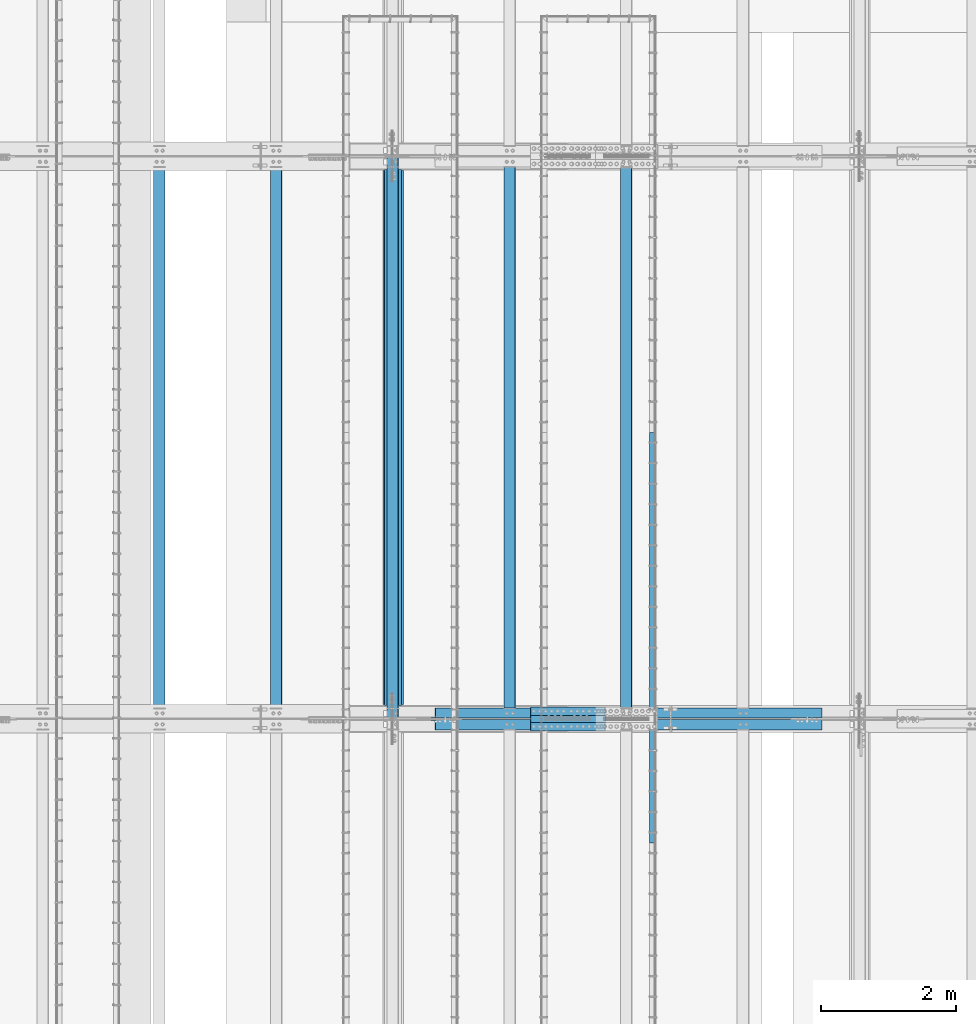
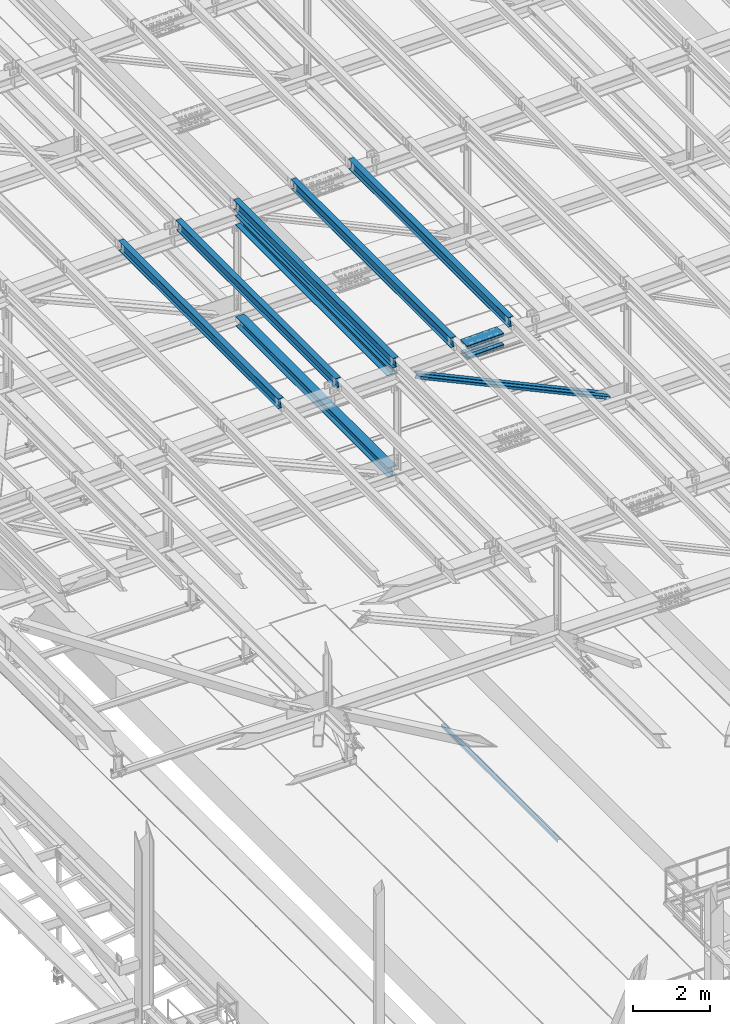
# One storey, part 1828 of 3843: 14 beams, 2 members, 11 elements without a shape of their own.
"""IFC2X3 building model written with IfcOpenShell, lengths in millimetres."""

from ifc_helpers import new_model, si_unit, frame, origin_with_axes, place, context, subcontext, project, spatial, faceted_brep, material, type_object, element, aggregate, save


model = new_model("IFC2X3")

# Units and contexts
model_context = context("Model", 3, precision=1e-05, world=origin_with_axes())
body_context = subcontext(model_context, "Body", "Model", "MODEL_VIEW")
ifc_project = project(units=[si_unit("LENGTHUNIT", "METRE", prefix="MILLI"), si_unit("AREAUNIT", "SQUARE_METRE"), si_unit("VOLUMEUNIT", "CUBIC_METRE"), si_unit("MASSUNIT", "GRAM", prefix="KILO"), si_unit("TIMEUNIT", "SECOND"), si_unit("PLANEANGLEUNIT", "RADIAN"), si_unit("SOLIDANGLEUNIT", "STERADIAN"), si_unit("THERMODYNAMICTEMPERATUREUNIT", "DEGREE_CELSIUS"), si_unit("LUMINOUSINTENSITYUNIT", "LUMEN")], contexts=[model_context])

# Site, building, storey
site_placement = place(None, origin_with_axes())
site = spatial("IfcSite", under=ifc_project, at=site_placement, CompositionType="ELEMENT")
building_placement = place(site_placement, origin_with_axes())
building = spatial("IfcBuilding", under=site, at=building_placement, Name="Undefined", CompositionType="ELEMENT")
storey_placement = place(building_placement, origin_with_axes())
storey = spatial("IfcBuildingStorey", under=building, at=storey_placement, Name="Undefined", CompositionType="ELEMENT", Elevation=0.0)

# Assembly, beam
assembly_1_placement = place(storey_placement, origin_with_axes())
assembly_1 = element("IfcElementAssembly", 1, at=assembly_1_placement, inside=storey, Name="EMBED_ANGLE", AssemblyPlace="NOTDEFINED", PredefinedType="RIGID_FRAME")
ifc_material_1 = material(Name="STEEL/A36")
beam_type_1 = type_object("IfcBeamType", Name="L3-1/2X3-1/2X5/16", PredefinedType="NOTDEFINED")
beam_1_placement = place(assembly_1_placement, frame((52851.7485419922, 46456.599609375, 30410.15), z_axis=(0.0, 0.0, -1.0), x_axis=(0.0, -1.0, 0.0)))
beam_1 = element("IfcBeam", 2, at=beam_1_placement, type_object=beam_type_1, material=ifc_material_1, Name="EMBED_ANGLE", ObjectType="L3-1/2X3-1/2X5/16", context=body_context, shape_type="Brep", body=[
    faceted_brep([(-3.63797880709171e-12, 44.4499999999971, -44.4500000000007), (-3.63797880709171e-12, 44.4499999999971, 44.4500000000007), (6096.0, 44.4499999999971, 44.4500000000007), (6096.0, 44.4499999999971, -44.4500000000007), (-3.63797880709171e-12, 36.5124999999971, 44.4500000000007), (6096.0, 36.5124999999971, 44.4500000000007), (-3.63797880709171e-12, 36.5124999999971, -36.5125000000007), (6096.0, 36.5124999999971, -36.5125000000007), (3.63797880709171e-12, -44.4499999999971, -36.5125000000007), (6096.0, -44.4499999999971, -36.5125000000007), (3.63797880709171e-12, -44.4499999999971, -44.4500000000007), (6096.0, -44.4499999999971, -44.4500000000007)], [[[0, 1, 2, 3]], [[1, 4, 5, 2]], [[4, 6, 7, 5]], [[6, 8, 9, 7]], [[8, 10, 11, 9]], [[10, 0, 3, 11]], [[5, 7, 9, 11, 3, 2]], [[10, 8, 6, 4, 1, 0]]]),
])
aggregate(assembly_1, [beam_1])

assembly_2_placement = place(storey_placement, origin_with_axes())
assembly_2 = element("IfcElementAssembly", 3, at=assembly_2_placement, inside=storey, Name="BEAM", AssemblyPlace="NOTDEFINED", PredefinedType="RIGID_FRAME")
ifc_material_2 = material(Name="STEEL/A992")
beam_type_2 = type_object("IfcBeamType", Name="W12X26", PredefinedType="NOTDEFINED")
beam_2_placement = place(assembly_2_placement, frame((48993.309262352, 42201.9275446702, 45888.5906251913), z_axis=(-0.0211520980083369, -0.00110850299980666, 0.999775654820093), x_axis=(0.0, 0.999999385335421, 0.00110875100037148)))
beam_2 = element("IfcBeam", 4, at=beam_2_placement, type_object=beam_type_2, material=ifc_material_2, Name="BEAM", ObjectType="W12X26", context=body_context, shape_type="Brep", body=[
    faceted_brep([(12.6980717942206, 82.5500000002139, -155.574999999408), (12.7086302911775, 82.5500000001921, -146.049999999421), (8343.91375117049, 82.5500000003813, -146.050000008639), (8343.90319267353, 82.5500000004031, -155.575000008612), (12.710491827158, 3.17500000034488, -146.049999999675), (8343.91561270646, 3.17500000053406, -146.050000008887), (13.0342857339128, 3.17499999964639, 146.049999999668), (8344.23940661321, 3.17499999983556, 146.049999990464), (13.0324241979324, 82.5499999994863, 146.049999999916), (8344.23754507724, 82.5499999996755, 146.049999990704), (13.0429826948894, 82.5499999994718, 155.574999999895), (8344.2481035742, 82.5499999996609, 155.574999990684), (13.0468546897246, -82.5500000002139, 155.574999999386), (8344.25197556902, -82.5500000000247, 155.574999990175), (13.0362961927676, -82.5500000001848, 146.049999999406), (8344.24141707207, -82.5499999999956, 146.049999990188), (13.0344346567872, -3.17500000034488, 146.049999999654), (8344.23955553609, -3.17500000015571, 146.049999990442), (12.7106407500323, -3.17499999963911, -146.04999999969), (8343.91576162934, -3.17499999944994, -146.050000008901), (12.7125022860055, -82.5499999994863, -146.049999999937), (8343.91762316532, -82.5499999992971, -146.050000009149), (12.7019437890485, -82.5499999994645, -155.57499999991), (8343.90706466835, -82.5499999992753, -155.575000009128)], [[[0, 1, 2, 3]], [[1, 4, 5, 2]], [[4, 6, 7, 5]], [[6, 8, 9, 7]], [[8, 10, 11, 9]], [[10, 12, 13, 11]], [[12, 14, 15, 13]], [[14, 16, 17, 15]], [[16, 18, 19, 17]], [[18, 20, 21, 19]], [[20, 22, 23, 21]], [[22, 0, 3, 23]], [[5, 7, 9, 11, 13, 15, 17, 19, 21, 23, 3, 2]], [[22, 20, 18, 16, 14, 12, 10, 8, 6, 4, 1, 0]]]),
])
aggregate(assembly_2, [beam_2])

assembly_3_placement = place(storey_placement, origin_with_axes())
assembly_3 = element("IfcElementAssembly", 5, at=assembly_3_placement, inside=storey, Name="BEAM", AssemblyPlace="NOTDEFINED", PredefinedType="RIGID_FRAME")
beam_3_placement = place(assembly_3_placement, frame((52460.4092622945, 42201.8902388067, 45971.7715925122), z_axis=(-0.0211520982424918, -0.00134829600025114, 0.999775360187395), x_axis=(0.0, 0.999999090641304, 0.00134859799951611)))
beam_3 = element("IfcBeam", 6, at=beam_3_placement, type_object=beam_type_2, material=ifc_material_2, Name="BEAM", ObjectType="W12X26", context=body_context, shape_type="Brep", body=[
    faceted_brep([(12.6976567514139, 82.5500000003303, -155.575000000208), (12.7104992851673, 82.5500000003085, -146.050000000199), (8343.91807537855, 82.5499999999302, -146.049999982519), (8343.9052328448, 82.549999999952, -155.57499998252), (12.7127635129655, 3.17500000043947, -146.050000000076), (8343.92033960635, 3.17500000006112, -146.04999998241), (13.106601214713, 3.1749999995518, 146.050000000134), (8344.3141773081, 3.17499999917345, 146.050000017814), (13.1043369869221, 82.5499999994136, 146.050000000025), (8344.3119130803, 82.5499999990352, 146.050000017698), (13.1171795206756, 82.5499999993917, 155.575000000033), (8344.32475561406, 82.5499999990134, 155.575000017707), (13.121889114489, -82.5500000003303, 155.575000000266), (8344.32946520787, -82.5500000007087, 155.575000017947), (13.1090465807356, -82.5500000003085, 146.050000000265), (8344.31662267412, -82.5500000006869, 146.050000017945), (13.1067823529447, -3.17500000043947, 146.050000000156), (8344.31435844633, -3.17500000081782, 146.050000017829), (12.7129446511899, -3.1749999995518, -146.050000000068), (8343.92052074457, -3.17499999993015, -146.049999982388), (12.7152088789881, -82.5499999994136, -146.049999999945), (8343.92278497236, -82.5499999997919, -146.049999982279), (12.7023663452273, -82.5499999993917, -155.574999999961), (8343.90994243861, -82.5499999997701, -155.574999982287)], [[[0, 1, 2, 3]], [[1, 4, 5, 2]], [[4, 6, 7, 5]], [[6, 8, 9, 7]], [[8, 10, 11, 9]], [[10, 12, 13, 11]], [[12, 14, 15, 13]], [[14, 16, 17, 15]], [[16, 18, 19, 17]], [[18, 20, 21, 19]], [[20, 22, 23, 21]], [[22, 0, 3, 23]], [[5, 7, 9, 11, 13, 15, 17, 19, 21, 23, 3, 2]], [[22, 20, 18, 16, 14, 12, 10, 8, 6, 4, 1, 0]]]),
])
aggregate(assembly_3, [beam_3])

assembly_4_placement = place(storey_placement, origin_with_axes())
assembly_4 = element("IfcElementAssembly", 7, at=assembly_4_placement, inside=storey, Name="BEAM", AssemblyPlace="NOTDEFINED", PredefinedType="RIGID_FRAME")
beam_4_placement = place(assembly_4_placement, frame((50726.859262296, 42201.9083142255, 45930.4266750726), z_axis=(-0.0211520980705027, -0.00123211200015067, 0.999775510125766), x_axis=(0.0, 0.999999240610853, 0.00123238699952042)))
beam_4 = element("IfcBeam", 8, at=beam_4_placement, type_object=beam_type_2, material=ifc_material_2, Name="BEAM", ObjectType="W12X26", context=body_context, shape_type="Brep", body=[
    faceted_brep([(12.6978578274429, 82.5500000001193, -155.575000000354), (12.7095936962578, 82.5500000001048, -146.050000000345), (8343.91592028135, 82.5500000007305, -146.050000029805), (8343.90418441253, 82.5500000007378, -155.575000029814), (12.7116628110161, 3.17500000023574, -146.050000000105), (8343.91798939612, 3.1750000008542, -146.05000002958), (13.0715627881727, 3.17499999975553, 146.050000000003), (8344.27788937327, 3.17500000037398, 146.04999997055), (13.0694936734144, 82.5499999996173, 146.049999999763), (8344.27582025851, 82.5500000002357, 146.049999970302), (13.0812295422365, 82.5499999996027, 155.574999999772), (8344.28755612733, 82.5500000002212, 155.574999970311), (13.0855333009458, -82.5500000001193, 155.575000000274), (8344.29185988603, -82.5499999994936, 155.574999970806), (13.0737974321237, -82.5500000000975, 146.050000000265), (8344.28012401721, -82.549999999479, 146.049999970804), (13.0717283173581, -3.17500000023574, 146.050000000017), (8344.27805490245, -3.17499999961001, 146.049999970564), (12.7118283402015, -3.17499999975553, -146.05000000009), (8343.9181549253, -3.17499999913707, -146.050000029558), (12.7138974549671, -82.5499999996173, -146.049999999843), (8343.92022404006, -82.5499999989916, -146.05000002931), (12.7021615861449, -82.5499999996027, -155.574999999852), (8343.90848817123, -82.549999998977, -155.575000029312)], [[[0, 1, 2, 3]], [[1, 4, 5, 2]], [[4, 6, 7, 5]], [[6, 8, 9, 7]], [[8, 10, 11, 9]], [[10, 12, 13, 11]], [[12, 14, 15, 13]], [[14, 16, 17, 15]], [[16, 18, 19, 17]], [[18, 20, 21, 19]], [[20, 22, 23, 21]], [[22, 0, 3, 23]], [[5, 7, 9, 11, 13, 15, 17, 19, 21, 23, 3, 2]], [[22, 20, 18, 16, 14, 12, 10, 8, 6, 4, 1, 0]]]),
])
aggregate(assembly_4, [beam_4])

assembly_5_placement = place(storey_placement, origin_with_axes())
assembly_5 = element("IfcElementAssembly", 9, at=assembly_5_placement, inside=storey, Name="BEAM", AssemblyPlace="NOTDEFINED", PredefinedType="RIGID_FRAME")
beam_5_placement = place(assembly_5_placement, frame((47259.7592622956, 42201.9479393539, 45846.2543835782), z_axis=(-0.0211520981155117, -0.00097741099957784, 0.999775791571815), x_axis=(0.0, 0.999999522120655, 0.000977629000118257)))
beam_5 = element("IfcBeam", 10, at=beam_5_placement, type_object=beam_type_2, material=ifc_material_2, Name="BEAM", ObjectType="W12X26", context=body_context, shape_type="Brep", body=[
    faceted_brep([(12.6982990667166, 82.5499999994063, -155.57500000007), (12.7076089040711, 82.5499999994354, -146.050000000047), (8343.91159024316, 82.5499999989988, -146.04999997947), (8343.90224609679, 82.5499999801978, -155.574999994402), (12.7092502928863, 3.17499999959546, -146.050000000258), (8343.91323163197, 3.1749999991589, -146.049999979667), (12.9947519717607, 3.17500000038854, 146.05000000033), (8344.19873331086, 3.17499999995198, 146.050000020921), (12.9931105829455, 82.5500000002285, 146.050000000541), (8344.19709192203, 82.5499999997919, 146.050000021118), (13.0024204203, 82.5500000002576, 155.575000000557), (8344.20640175939, 82.549999999821, 155.575000021148), (13.0058345090365, -82.5499999994063, 155.575000000128), (8344.20981584812, -82.5499999998428, 155.575000020712), (12.996524671682, -82.5499999994354, 146.050000000112), (8344.20050601077, -82.5499999998719, 146.050000020696), (12.9948832828668, -3.17499999959546, 146.050000000323), (8344.19886462195, -3.17500000003201, 146.050000020899), (12.7093816039924, -3.17500000038854, -146.050000000272), (8343.91336294308, -3.17500000082509, -146.049999979688), (12.7110229928076, -82.5500000002212, -146.050000000483), (8343.9150043319, -82.5500000006577, -146.049999979892), (12.7017131554458, -82.5500000002576, -155.575000000499), (8343.90569449455, -82.5500000006941, -155.574999979923)], [[[0, 1, 2, 3]], [[1, 4, 5, 2]], [[4, 6, 7, 5]], [[6, 8, 9, 7]], [[8, 10, 11, 9]], [[10, 12, 13, 11]], [[12, 14, 15, 13]], [[14, 16, 17, 15]], [[16, 18, 19, 17]], [[18, 20, 21, 19]], [[20, 22, 23, 21]], [[22, 0, 3, 23]], [[5, 7, 9, 11, 13, 15, 17, 19, 21, 23, 3, 2]], [[22, 20, 18, 16, 14, 12, 10, 8, 6, 4, 1, 0]]]),
])
aggregate(assembly_5, [beam_5])

assembly_6_placement = place(storey_placement, origin_with_axes())
assembly_6 = element("IfcElementAssembly", 11, at=assembly_6_placement, inside=storey, Name="BEAM", AssemblyPlace="NOTDEFINED", PredefinedType="RIGID_FRAME")
beam_6_placement = place(assembly_6_placement, frame((45526.209262296, 42201.9695298362, 45803.4044011888), z_axis=(-0.0211520984488161, -0.000838631999671634, 0.999775917607331), x_axis=(0.0, 0.999999648190442, 0.000838820000159733)))
beam_6 = element("IfcBeam", 12, at=beam_6_placement, type_object=beam_type_2, material=ifc_material_2, Name="BEAM", ObjectType="W12X26", context=body_context, shape_type="Brep", body=[
    faceted_brep([(12.6985397381141, 82.5499999995518, -155.575000000288), (12.7065277138609, 82.5499999995591, -146.050000000272), (8343.90945875162, 82.54999999953, -146.049999998671), (8343.9014659344, 82.5499999790045, -155.574999985372), (12.7079360494827, 3.17499999971915, -146.050000000258), (8343.91086708724, 3.17499999969004, -146.049999998664), (12.9529006390876, 3.17500000025757, 146.050000000279), (8344.15583167685, 3.17500000022847, 146.050000001873), (12.9514923034731, 82.5500000000975, 146.050000000272), (8344.15442334124, 82.5500000000684, 146.050000001858), (12.9594802792199, 82.5500000001193, 155.575000000281), (8344.16241131699, 82.5500000000829, 155.575000001889), (12.9624096173065, -82.5499999995591, 155.575000000295), (8344.16534065507, -82.5499999995882, 155.575000001903), (12.9544216415597, -82.5499999995736, 146.050000000287), (8344.15735267932, -82.54999999961, 146.050000001887), (12.9530133059379, -3.17499999972642, 146.050000000279), (8344.15594434371, -3.1749999997628, 146.050000001873), (12.7080487163257, -3.17500000026484, -146.050000000258), (8343.9109797541, -3.17500000029395, -146.049999998664), (12.7094570519475, -82.5500000001048, -146.05000000025), (8343.91238808972, -82.5500000001339, -146.049999998657), (12.7014690762007, -82.5500000001339, -155.575000000266), (8343.90440011397, -82.550000000163, -155.57499999868)], [[[0, 1, 2, 3]], [[1, 4, 5, 2]], [[4, 6, 7, 5]], [[6, 8, 9, 7]], [[8, 10, 11, 9]], [[10, 12, 13, 11]], [[12, 14, 15, 13]], [[14, 16, 17, 15]], [[16, 18, 19, 17]], [[18, 20, 21, 19]], [[20, 22, 23, 21]], [[22, 0, 3, 23]], [[5, 7, 9, 11, 13, 15, 17, 19, 21, 23, 3, 2]], [[22, 20, 18, 16, 14, 12, 10, 8, 6, 4, 1, 0]]]),
])
aggregate(assembly_6, [beam_6])

# Assembly, beams
assembly_7_placement = place(storey_placement, origin_with_axes())
assembly_7 = element("IfcElementAssembly", 13, at=assembly_7_placement, inside=storey, Name="BEAM", AssemblyPlace="NOTDEFINED", PredefinedType="RIGID_FRAME")
ifc_material_3 = material(Name="STEEL/A572-50")
beam_type_3 = type_object("IfcBeamType", PredefinedType="NOTDEFINED")
beam_7_placement = place(assembly_7_placement, frame((51036.2821626709, 42316.4, 45732.9991056913), z_axis=(0.0, -1.0, 0.0), x_axis=(0.999715775508226, 0.0, 0.0238404739882768)))
beam_7 = element("IfcBeam", 14, at=beam_7_placement, type_object=beam_type_3, material=ifc_material_3, Name="PLATE", context=body_context, shape_type="Brep", body=[
    faceted_brep([(-4.36557456851006e-11, 12.7000000000116, -63.5), (-4.36557456851006e-11, 12.7000000000116, 63.5), (1104.90000001677, 12.7000000017251, 63.5), (1104.90000001677, 12.7000000017251, -63.5), (1.45519152283669e-11, -12.700000000008, 63.5), (1104.90000001682, -12.6999999982909, 63.5), (1.45519152283669e-11, -12.700000000008, -63.5), (1104.90000001682, -12.6999999982909, -63.5)], [[[0, 1, 2, 3]], [[1, 4, 5, 2]], [[4, 6, 7, 5]], [[6, 0, 3, 7]], [[5, 7, 3, 2]], [[6, 4, 1, 0]]]),
])
beam_8_placement = place(assembly_7_placement, frame((51043.3215559645, 42316.4, 45437.8123355448), z_axis=(0.0, -1.0, 0.0), x_axis=(0.999715775508226, 0.0, 0.0238404739882768)))
beam_8 = element("IfcBeam", 15, at=beam_8_placement, type_object=beam_type_3, material=ifc_material_3, Name="PLATE", context=body_context, shape_type="Brep", body=[
    faceted_brep([(-4.36557456851006e-11, 12.7000000000116, -63.5), (-4.36557456851006e-11, 12.7000000000116, 63.5), (1104.90000001677, 12.7000000017251, 63.5), (1104.90000001677, 12.7000000017251, -63.5), (1.45519152283669e-11, -12.700000000008, 63.5), (1104.90000001682, -12.6999999982909, 63.5), (1.45519152283669e-11, -12.700000000008, -63.5), (1104.90000001682, -12.6999999982909, -63.5)], [[[0, 1, 2, 3]], [[1, 4, 5, 2]], [[4, 6, 7, 5]], [[6, 0, 3, 7]], [[5, 7, 3, 2]], [[6, 4, 1, 0]]]),
])
beam_9_placement = place(assembly_7_placement, frame((51036.2821626709, 42087.8, 45732.9991056913), z_axis=(0.0, -1.0, 0.0), x_axis=(0.999715775508226, 0.0, 0.0238404739882768)))
beam_9 = element("IfcBeam", 16, at=beam_9_placement, type_object=beam_type_3, material=ifc_material_3, Name="PLATE", context=body_context, shape_type="Brep", body=[
    faceted_brep([(-4.36557456851006e-11, 12.7000000000116, -63.5), (-4.36557456851006e-11, 12.7000000000116, 63.5), (1104.90000001677, 12.7000000017251, 63.5), (1104.90000001677, 12.7000000017251, -63.5), (1.45519152283669e-11, -12.700000000008, 63.5), (1104.90000001682, -12.6999999982909, 63.5), (1.45519152283669e-11, -12.700000000008, -63.5), (1104.90000001682, -12.6999999982909, -63.5)], [[[0, 1, 2, 3]], [[1, 4, 5, 2]], [[4, 6, 7, 5]], [[6, 0, 3, 7]], [[5, 7, 3, 2]], [[6, 4, 1, 0]]]),
])
beam_10_placement = place(assembly_7_placement, frame((51043.3215559645, 42087.8, 45437.8123355448), z_axis=(0.0, -1.0, 0.0), x_axis=(0.999715775508226, 0.0, 0.0238404739882768)))
beam_10 = element("IfcBeam", 17, at=beam_10_placement, type_object=beam_type_3, material=ifc_material_3, Name="PLATE", context=body_context, shape_type="Brep", body=[
    faceted_brep([(-4.36557456851006e-11, 12.7000000000116, -63.5), (-4.36557456851006e-11, 12.7000000000116, 63.5), (1104.90000001677, 12.7000000017251, 63.5), (1104.90000001677, 12.7000000017251, -63.5), (1.45519152283669e-11, -12.700000000008, 63.5), (1104.90000001682, -12.6999999982909, 63.5), (1.45519152283669e-11, -12.700000000008, -63.5), (1104.90000001682, -12.6999999982909, -63.5)], [[[0, 1, 2, 3]], [[1, 4, 5, 2]], [[4, 6, 7, 5]], [[6, 0, 3, 7]], [[5, 7, 3, 2]], [[6, 4, 1, 0]]]),
])
beam_type_4 = type_object("IfcBeamType", PredefinedType="NOTDEFINED")
beam_11_placement = place(assembly_7_placement, frame((52139.3904600883, 42202.1, 45821.3041020251), z_axis=(0.0, -1.0, 0.0), x_axis=(-0.999715775508227, 0.0, -0.0238404739882678)))
beam_11 = element("IfcBeam", 18, at=beam_11_placement, type_object=beam_type_4, material=ifc_material_3, Name="PLATE", context=body_context, shape_type="Brep", body=[
    faceted_brep([(-1.45519152283669e-11, 12.7000000000025, -177.800000000003), (-1.45519152283669e-11, 12.7000000000025, 177.800000000003), (1104.90000001682, 12.7000000017051, 177.800000000003), (1104.90000001682, 12.7000000017051, -177.800000000003), (4.36557456851006e-11, -12.7000000000171, 177.800000000003), (1104.90000001686, -12.6999999983072, 177.800000000003), (4.36557456851006e-11, -12.7000000000171, -177.800000000003), (1104.90000001686, -12.6999999983072, -177.800000000003)], [[[0, 1, 2, 3]], [[1, 4, 5, 2]], [[4, 6, 7, 5]], [[6, 0, 3, 7]], [[5, 7, 3, 2]], [[6, 4, 1, 0]]]),
])
beam_12_placement = place(assembly_7_placement, frame((52149.3857265386, 42202.1, 45402.2588242328), z_axis=(0.0, -1.0, 0.0), x_axis=(-0.999715775508227, 0.0, -0.0238404739882678)))
beam_12 = element("IfcBeam", 19, at=beam_12_placement, type_object=beam_type_4, material=ifc_material_3, Name="PLATE", context=body_context, shape_type="Brep", body=[
    faceted_brep([(-1.45519152283669e-11, 12.7000000000025, -177.800000000003), (-1.45519152283669e-11, 12.7000000000025, 177.800000000003), (1104.90000001682, 12.7000000017051, 177.800000000003), (1104.90000001682, 12.7000000017051, -177.800000000003), (4.36557456851006e-11, -12.7000000000171, 177.800000000003), (1104.90000001686, -12.6999999983072, 177.800000000003), (4.36557456851006e-11, -12.7000000000171, -177.800000000003), (1104.90000001686, -12.6999999983072, -177.800000000003)], [[[0, 1, 2, 3]], [[1, 4, 5, 2]], [[4, 6, 7, 5]], [[6, 0, 3, 7]], [[5, 7, 3, 2]], [[6, 4, 1, 0]]]),
])
aggregate(assembly_7, [beam_7, beam_8, beam_9, beam_10, beam_11, beam_12])

# Assembly, member
assembly_8_placement = place(storey_placement, origin_with_axes())
assembly_8 = element("IfcElementAssembly", 20, at=assembly_8_placement, inside=storey, Name="ANGLE", AssemblyPlace="NOTDEFINED", PredefinedType="RIGID_FRAME")
member_type = type_object("IfcMemberType", Name="L6X6X1/2", PredefinedType="NOTDEFINED")
member_1_placement = place(assembly_8_placement, frame((48996.5999997284, 42287.825, 45536.1429226024), z_axis=(-0.421177373026855, 0.0, -0.906978291057839), x_axis=(0.906978291057838, 0.0, -0.421177373026857)))
member_1 = element("IfcMember", 21, at=member_1_placement, type_object=member_type, material=ifc_material_3, Name="ANGLE", ObjectType="L6X6X1/2", context=body_context, shape_type="Brep", body=[
    faceted_brep([(655.376403827697, 76.1999999999971, -76.2000000000626), (655.376403827697, 76.1999999999971, 76.2000000001717), (6990.08542977147, 76.1999999999971, 76.200000000812), (6990.08542977147, 76.1999999999971, -76.1999999994296), (655.376403827697, 63.5, 76.2000000001717), (6990.08542977147, 63.5, 76.200000000812), (655.3764038277, 63.5, -63.5000000000437), (6990.08542977146, 63.5, -63.4999999994106), (655.3764038277, -76.1999999999971, -63.5000000000437), (6990.08542977146, -76.1999999999971, -63.4999999994106), (655.376403827697, -76.1999999999971, -76.2000000000626), (6990.08542977147, -76.1999999999971, -76.1999999994296)], [[[0, 1, 2, 3]], [[1, 4, 5, 2]], [[4, 6, 7, 5]], [[6, 8, 9, 7]], [[8, 10, 11, 9]], [[10, 0, 3, 11]], [[5, 7, 9, 11, 3, 2]], [[10, 8, 6, 4, 1, 0]]]),
])
aggregate(assembly_8, [member_1])

assembly_9_placement = place(storey_placement, origin_with_axes())
assembly_9 = element("IfcElementAssembly", 22, at=assembly_9_placement, inside=storey, Name="ANGLE", AssemblyPlace="NOTDEFINED", PredefinedType="RIGID_FRAME")
member_2_placement = place(assembly_9_placement, frame((55930.799998912, 42116.375, 42316.0789233202), z_axis=(-0.421177373026855, 0.0, -0.906978291057839), x_axis=(-0.906978291057838, 0.0, 0.421177373026857)))
member_2 = element("IfcMember", 23, at=member_2_placement, type_object=member_type, material=ifc_material_3, Name="ANGLE", ObjectType="L6X6X1/2", context=body_context, shape_type="Brep", body=[
    faceted_brep([(655.301531561163, 76.1999999999971, -76.200000000179), (655.301531561163, 76.1999999999971, 76.200000000048), (6990.01055750492, 76.1999999999971, 76.199999999415), (6990.01055750493, 76.1999999999971, -76.2000000008265), (655.301531561163, 63.5, 76.200000000048), (6990.01055750492, 63.5, 76.199999999415), (655.301531561159, 63.5, -63.5000000001601), (6990.01055750492, 63.5, -63.5000000008076), (655.301531561159, -76.1999999999971, -63.5000000001601), (6990.01055750492, -76.1999999999971, -63.5000000008076), (655.301531561163, -76.1999999999971, -76.200000000179), (6990.01055750493, -76.1999999999971, -76.2000000008265)], [[[0, 1, 2, 3]], [[1, 4, 5, 2]], [[4, 6, 7, 5]], [[6, 8, 9, 7]], [[8, 10, 11, 9]], [[10, 0, 3, 11]], [[5, 7, 9, 11, 3, 2]], [[10, 8, 6, 4, 1, 0]]]),
])
aggregate(assembly_9, [member_2])

# Assembly, beam
assembly_10_placement = place(storey_placement, origin_with_axes())
assembly_10 = element("IfcElementAssembly", 24, at=assembly_10_placement, inside=storey, Name="BEAM", AssemblyPlace="NOTDEFINED", PredefinedType="RIGID_FRAME")
beam_type_5 = type_object("IfcBeamType", Name="W12X65", PredefinedType="NOTDEFINED")
beam_13_placement = place(assembly_10_placement, frame((48996.6, 42202.0999999998, 45536.140030933), z_axis=(0.0, -0.00110875100037083, 0.999999385335421), x_axis=(0.0, 0.999999385335421, 0.00110875100037148)))
beam_13 = element("IfcBeam", 25, at=beam_13_placement, type_object=beam_type_5, material=ifc_material_2, Name="BEAM", ObjectType="W12X65", context=body_context, shape_type="Brep", body=[
    faceted_brep([(212.554396854728, 152.400000000001, -153.987500000068), (212.571998287684, 152.400000000001, -138.112500000083), (8143.72687327107, 152.400000000001, -138.11250000885), (8143.70927183812, 152.400000000001, -153.987500008829), (212.571998287684, 4.76249999999709, -138.112500000083), (8143.72687327107, 4.76249999999709, -138.11250000885), (212.878263221006, 4.76249999999709, 138.112499999625), (8144.0331382044, 4.76249999999709, 138.112499990857), (212.878263221006, 152.400000000001, 138.112499999625), (8144.0331382044, 152.400000000001, 138.112499990857), (212.895864653961, 152.400000000001, 153.98749999961), (8144.05073963735, 152.400000000001, 153.98749999085), (212.895864653961, -152.400000000001, 153.98749999961), (8144.05073963735, -152.400000000001, 153.98749999085), (212.878263221006, -152.400000000001, 138.112499999625), (8144.0331382044, -152.400000000001, 138.112499990857), (212.878263221006, -4.76249999999709, 138.112499999625), (8144.0331382044, -4.76249999999709, 138.112499990857), (212.571998287684, -4.76249999999709, -138.112500000083), (8143.72687327107, -4.76249999999709, -138.11250000885), (212.571998287684, -152.400000000001, -138.112500000083), (8143.72687327107, -152.400000000001, -138.11250000885), (212.554396854728, -152.400000000001, -153.987500000068), (8143.70927183812, -152.400000000001, -153.987500008829)], [[[0, 1, 2, 3]], [[1, 4, 5, 2]], [[4, 6, 7, 5]], [[6, 8, 9, 7]], [[8, 10, 11, 9]], [[10, 12, 13, 11]], [[12, 14, 15, 13]], [[14, 16, 17, 15]], [[16, 18, 19, 17]], [[18, 20, 21, 19]], [[20, 22, 23, 21]], [[22, 0, 3, 23]], [[5, 7, 9, 11, 13, 15, 17, 19, 21, 23, 3, 2]], [[22, 20, 18, 16, 14, 12, 10, 8, 6, 4, 1, 0]]]),
])
aggregate(assembly_10, [beam_13])

assembly_11_placement = place(storey_placement, origin_with_axes())
assembly_11 = element("IfcElementAssembly", 26, at=assembly_11_placement, inside=storey, Name="BEAM", AssemblyPlace="NOTDEFINED", PredefinedType="RIGID_FRAME")
beam_type_6 = type_object("IfcBeamType", Name="W12X53", PredefinedType="NOTDEFINED")
beam_14_placement = place(assembly_11_placement, frame((48996.6, 42202.1, 42298.4573158048), z_axis=(0.0, -0.00110594200048945, 0.999999388445959), x_axis=(0.0, 0.999999388445959, 0.0011059420004928)))
beam_14 = element("IfcBeam", 27, at=beam_14_placement, type_object=beam_type_6, material=ifc_material_2, Name="BEAM", ObjectType="W12X53", context=body_context, shape_type="Brep", body=[
    faceted_brep([(198.269075692377, 127.0, -152.400000000598), (198.284876848375, 127.0, -138.112500000556), (8158.01474469355, 127.0, -138.112500009178), (8157.99894353756, 127.0, -152.400000009213), (198.284876848375, 4.76249999999709, -138.112500000556), (8158.01474469355, 4.76249999999709, -138.112500009178), (198.590365864278, 4.76249999999709, 138.112500000134), (8158.32023370946, 4.76249999999709, 138.112499991519), (198.590365864278, 127.0, 138.112500000134), (8158.32023370946, 127.0, 138.112499991519), (198.606167020276, 127.0, 152.400000000176), (8158.33603486546, 127.0, 152.399999991554), (198.606167020276, -127.0, 152.400000000176), (8158.33603486546, -127.0, 152.399999991554), (198.590365864278, -127.0, 138.112500000134), (8158.32023370946, -127.0, 138.112499991519), (198.590365864278, -4.76249999999709, 138.112500000134), (8158.32023370946, -4.76249999999709, 138.112499991519), (198.284876848375, -4.76249999999709, -138.112500000556), (8158.01474469355, -4.76249999999709, -138.112500009178), (198.284876848375, -127.0, -138.112500000556), (8158.01474469355, -127.0, -138.112500009178), (198.269075692377, -127.0, -152.400000000598), (8157.99894353756, -127.0, -152.400000009213)], [[[0, 1, 2, 3]], [[1, 4, 5, 2]], [[4, 6, 7, 5]], [[6, 8, 9, 7]], [[8, 10, 11, 9]], [[10, 12, 13, 11]], [[12, 14, 15, 13]], [[14, 16, 17, 15]], [[16, 18, 19, 17]], [[18, 20, 21, 19]], [[20, 22, 23, 21]], [[22, 0, 3, 23]], [[5, 7, 9, 11, 13, 15, 17, 19, 21, 23, 3, 2]], [[22, 20, 18, 16, 14, 12, 10, 8, 6, 4, 1, 0]]]),
])
aggregate(assembly_11, [beam_14])

save(model, "model.ifc")
